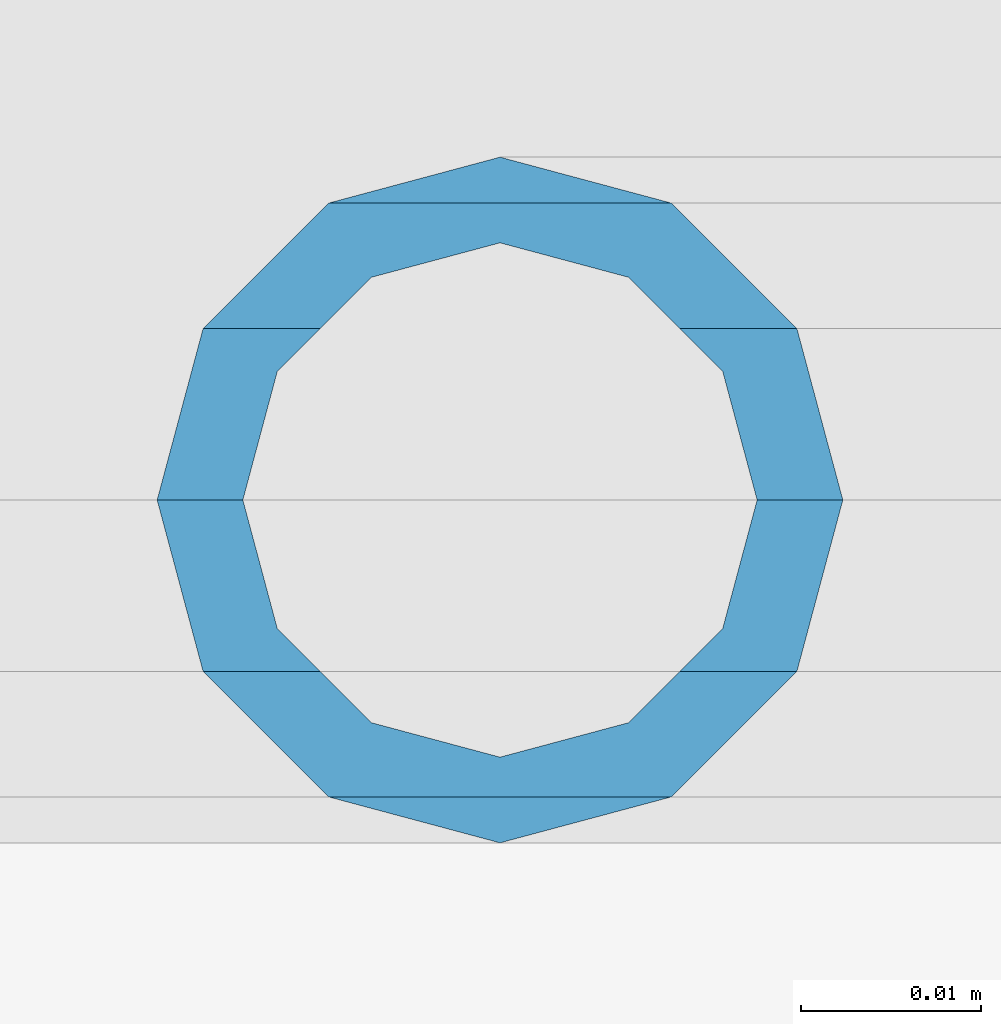
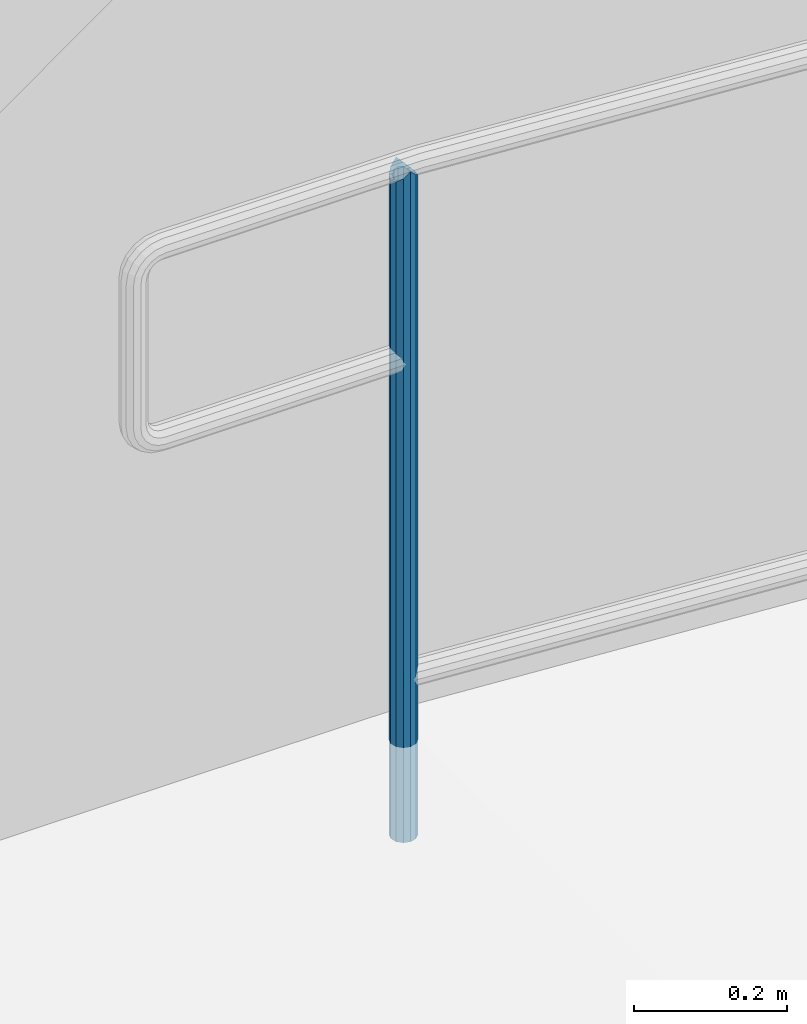
# One storey, part 901 of 1763: 1 column, 1 element without a shape of its own.
"""IFC2X3 building model written with IfcOpenShell, lengths in millimetres."""

from ifc_helpers import new_model, si_unit, frame, origin_with_axes, place, context, subcontext, project, spatial, faceted_brep, material, type_object, element, aggregate, save


model = new_model("IFC2X3")

# Units and contexts
model_context = context("Model", 3, precision=1e-05, world=origin_with_axes())
body_context = subcontext(model_context, "Body", "Model", "MODEL_VIEW")
ifc_project = project(units=[si_unit("LENGTHUNIT", "METRE", prefix="MILLI"), si_unit("AREAUNIT", "SQUARE_METRE"), si_unit("VOLUMEUNIT", "CUBIC_METRE"), si_unit("MASSUNIT", "GRAM", prefix="KILO"), si_unit("TIMEUNIT", "SECOND"), si_unit("PLANEANGLEUNIT", "RADIAN"), si_unit("SOLIDANGLEUNIT", "STERADIAN"), si_unit("THERMODYNAMICTEMPERATUREUNIT", "DEGREE_CELSIUS"), si_unit("LUMINOUSINTENSITYUNIT", "LUMEN")], contexts=[model_context])

# Site, building, storey
site_placement = place(None, origin_with_axes())
site = spatial("IfcSite", under=ifc_project, at=site_placement, CompositionType="ELEMENT")
building_placement = place(site_placement, origin_with_axes())
building = spatial("IfcBuilding", under=site, at=building_placement, Name="Undefined", CompositionType="ELEMENT")
storey_placement = place(building_placement, origin_with_axes())
storey = spatial("IfcBuildingStorey", under=building, at=storey_placement, Name="Undefined", CompositionType="ELEMENT", Elevation=0.0)

# Assembly, column
assembly_placement = place(storey_placement, origin_with_axes())
assembly = element("IfcElementAssembly", 1, at=assembly_placement, inside=storey, Name="GUARDRAIL", AssemblyPlace="NOTDEFINED", PredefinedType="RIGID_FRAME")
ifc_material = material()
column_type = type_object("IfcColumnType", PredefinedType="NOTDEFINED")
column_placement = place(assembly_placement, frame((-85889.5372736983, 29197.2999999971, 152.4), z_axis=(0.0, -1.0, 0.0), x_axis=(0.0, 0.0, 1.0)))
column = element("IfcColumn", 2, at=column_placement, type_object=column_type, material=ifc_material, Name="POST TUBE", context=body_context, shape_type="Brep", body=[
    faceted_brep([(1066.8, 0.0, -19.0499999999993), (1057.275001397, 9.52499999999418, -16.4977839420935), (1057.275002159, -9.52499999999418, -16.4977839420935), (1049.6641633263, 12.3733379565674, 7.14374999999927), (1047.7500012065, 14.2875000000058, 0.0), (1047.750001016, 19.0500000000029, 0.0), (1050.302217176, 16.4977839420899, 9.52500000000146), (1050.30221743622, 9.99208795657614, 9.52500000000146), (1050.30221743622, 9.99208795657614, -9.52500000000146), (1050.302217176, 16.4977839420899, -9.52500000000146), (1049.6641633263, 12.3733379565674, -7.14374999999927), (1053.15055550654, 7.14375000000291, -12.373337956571), (1055.06471783575, 0.0, -14.2874999999985), (1053.15055607809, -7.14375000000291, -12.373337956571), (1050.30221823559, -9.99208795657614, -9.52500000000146), (1050.30221849582, -16.4977839420899, -9.52500000000146), (1049.66416431624, -12.3733379565674, -7.14374999999927), (1047.7500023495, -14.2875000000058, 0.0), (1047.75000254, -19.0500000000029, 0.0), (1049.66416431624, -12.3733379565674, 7.14374999999927), (1050.30221823559, -9.99208795657614, 9.52500000000146), (1050.30221849582, -16.4977839420899, 9.52500000000146), (1066.800001778, 0.0, 19.0499999999993), (1057.275002159, -9.52499999999418, 16.4977839420935), (1057.275001397, 9.52499999999418, 16.4977839420935), (1053.15055607809, -7.14375000000291, 12.373337956571), (1055.06471783575, 0.0, 14.2874999999985), (1053.15055550654, 7.14375000000291, 12.373337956571), (0.0, -16.4977839420899, -9.52500000000146), (0.0, -9.52499999999418, -16.4977839420935), (1.45519152283669e-11, 1.81898940354586e-12, -19.0499999999993), (0.0, 9.52499999999418, -16.4977839420935), (0.0, 16.4977839420899, -9.52500000000146), (0.0, 19.0500000000029, 0.0), (0.0, 16.4977839420899, 9.52500000000146), (0.0, 9.52499999999418, 16.4977839420935), (1.45519152283669e-11, 1.81898940354586e-12, 19.0499999999993), (0.0, -16.4977839420899, 9.52500000000146), (0.0, -19.0500000000029, 0.0), (0.0, -9.52499999999418, 16.4977839420935), (0.0, -12.3733379565674, -7.14374999999927), (0.0, -7.14375000000291, -12.373337956571), (0.0, 0.0, -14.2874999999985), (0.0, 7.14375000000291, -12.373337956571), (0.0, 12.3733379565674, -7.14374999999927), (0.0, 14.2875000000058, 0.0), (0.0, 12.3733379565674, 7.14374999999927), (0.0, 7.14375000000291, 12.373337956571), (0.0, 0.0, 14.2874999999985), (0.0, -7.14375000000291, 12.373337956571), (0.0, -12.3733379565674, 7.14374999999927), (0.0, -14.2875000000058, 0.0)], [[[0, 1, 2]], [[3, 4, 5, 6, 7]], [[8, 9, 5, 4, 10]], [[2, 1, 9, 8, 11, 12, 13, 14, 15]], [[15, 14, 16, 17, 18]], [[18, 17, 19, 20, 21]], [[22, 23, 24]], [[21, 20, 25, 26, 27, 7, 6, 24, 23]], [[28, 29, 2, 15]], [[29, 30, 0, 2]], [[30, 31, 1, 0]], [[31, 32, 9, 1]], [[32, 33, 5, 9]], [[33, 34, 6, 5]], [[34, 35, 24, 6]], [[35, 36, 22, 24]], [[37, 38, 18, 21]], [[39, 37, 21, 23]], [[36, 39, 23, 22]], [[38, 28, 15, 18]], [[37, 39, 36, 35, 34, 33, 32, 31, 30, 29, 28, 38], [40, 41, 42, 43, 44, 45, 46, 47, 48, 49, 50, 51]], [[49, 48, 26, 25]], [[19, 50, 49, 25, 20]], [[51, 50, 19, 17]], [[40, 51, 17, 16]], [[41, 40, 16, 14, 13]], [[42, 41, 13, 12]], [[43, 42, 12, 11]], [[10, 44, 43, 11, 8]], [[45, 44, 10, 4]], [[46, 45, 4, 3]], [[47, 46, 3, 7, 27]], [[48, 47, 27, 26]]]),
])
aggregate(assembly, [column])

save(model, "model.ifc")
